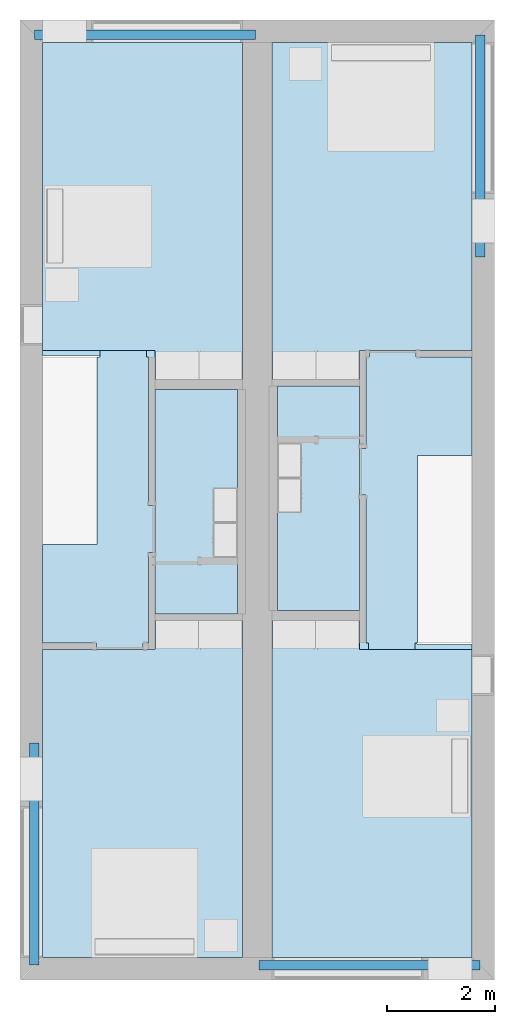
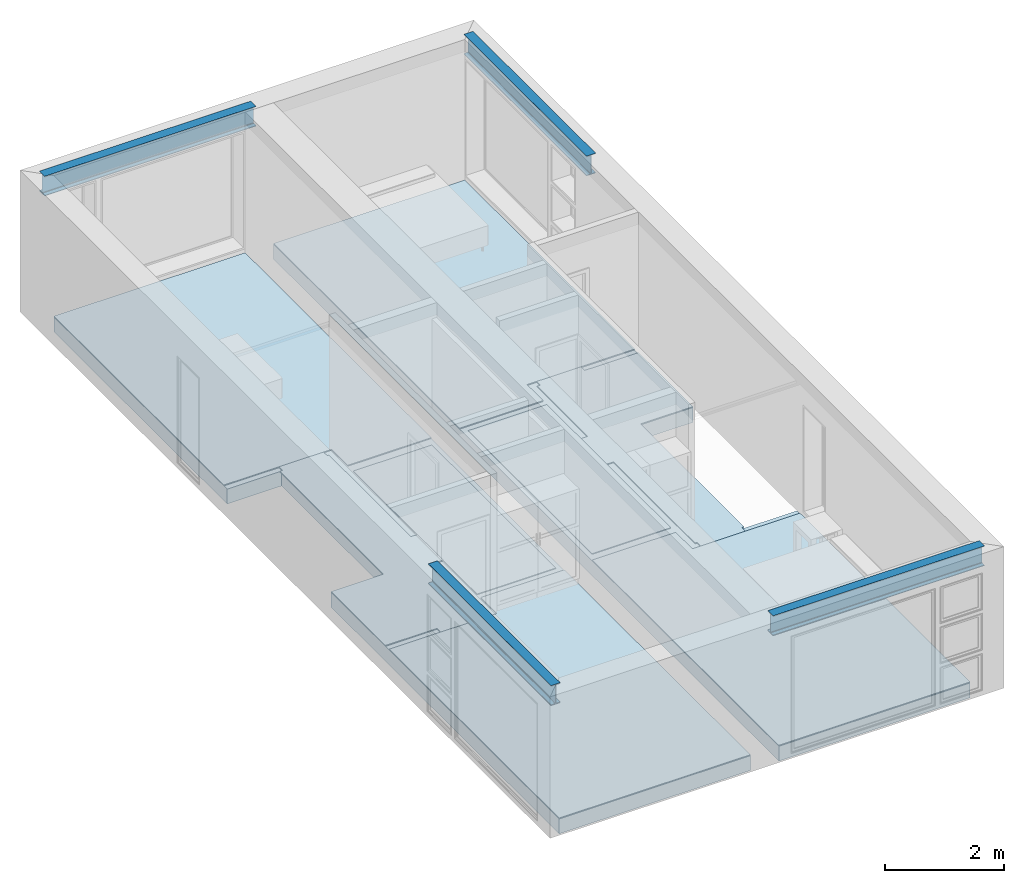
# One storey, part 1 of 16: 10 slabs, 4 beams.
"""IFC2X3 building model written with IfcOpenShell, lengths in metres."""

import ifcopenshell
import ifcopenshell.guid

model = None  # the IFC model being written
_history = None  # IfcOwnerHistory: only IFC2X3 demands one
_inside = {}  # id of a spatial element -> (the spatial element, [elements in it])
_under = {}  # id of a project, library or spatial element -> (it, [spatial elements below it])
_declared = {}  # id of a project -> (the project, [libraries it declares])
_typed = {}  # id of a type object -> (the type object, [elements of that type])
_made_of = {}  # id of a material, layer set ... -> (it, [elements and type objects made of it])


def new_model(schema):
    """Start an empty IFC model of exactly this schema.

    Asked for "IFC4X3", IfcOpenShell would pick the latest addendum, in which some entities
    have other attributes; the version numbers below select the first issue.
    IFC2X3 requires an IfcOwnerHistory on every rooted entity: one is made here for all.
    """
    global model, _history
    if schema == "IFC4X3":
        model = ifcopenshell.file(schema_version=(4, 3, 0, 0))
    else:
        model = ifcopenshell.file(schema=schema)
    _inside.clear()
    _under.clear()
    _declared.clear()
    _typed.clear()
    _made_of.clear()
    _history = None
    if model.schema == "IFC2X3":
        org = make("IfcOrganization", Name="unknown")
        user = make(
            "IfcPersonAndOrganization",
            ThePerson=make("IfcPerson", FamilyName="unknown"),
            TheOrganization=org,
        )
        app = make(
            "IfcApplication",
            ApplicationDeveloper=org,
            Version="unknown",
            ApplicationFullName="unknown",
            ApplicationIdentifier="unknown",
        )
        _history = make(
            "IfcOwnerHistory",
            OwningUser=user,
            OwningApplication=app,
            ChangeAction="ADDED",
            CreationDate=0,
        )
    return model


def make(cls, **values):
    """One entity of the class cls with the attributes given. An attribute that is None is left unset."""
    return model.create_entity(
        cls, **{name: value for name, value in values.items() if value is not None}
    )


def entity(cls, *values):
    """Any entity or typed value of the class cls, its attributes in the order of the schema. None: left unset."""
    e = model.create_entity(cls)
    for i, value in enumerate(values):
        if value is not None:
            e[i] = value
    return e


def rooted(cls, **values):
    """An entity with a GlobalId (a new one), such as an element, a storey or a relation."""
    return make(cls, GlobalId=ifcopenshell.guid.new(), OwnerHistory=_history, **values)


def si_unit(unit_type, name, prefix=None):
    """IfcSIUnit, for example si_unit("LENGTHUNIT", "METRE", prefix="MILLI")."""
    return make("IfcSIUnit", UnitType=unit_type, Prefix=prefix, Name=name)


def converted_unit(unit_type, name, factor, base, dimensions=None, offset=None):
    """IfcConversionBasedUnit, such as the inch: factor (a typed value) times the base unit."""
    return make(
        "IfcConversionBasedUnit"
        if offset is None
        else "IfcConversionBasedUnitWithOffset",
        ConversionOffset=offset,
        Dimensions=None
        if dimensions is None
        else entity("IfcDimensionalExponents", *dimensions),
        UnitType=unit_type,
        Name=name,
        ConversionFactor=make(
            "IfcMeasureWithUnit", ValueComponent=factor, UnitComponent=base
        ),
    )


def assignment(units):
    """IfcUnitAssignment: the units of a project."""
    return None if units is None else make("IfcUnitAssignment", Units=units)


def point(xyz):
    """IfcCartesianPoint."""
    return None if xyz is None else make("IfcCartesianPoint", Coordinates=xyz)


def direction(xyz):
    """IfcDirection."""
    return None if xyz is None else make("IfcDirection", DirectionRatios=xyz)


def frame(location, z_axis=None, x_axis=None):
    """IfcAxis2Placement3D, a coordinate frame: its origin and axes. An axis left out is left unset."""
    return make(
        "IfcAxis2Placement3D",
        Location=point(location),
        Axis=direction(z_axis),
        RefDirection=direction(x_axis),
    )


def frame_2d(location, x_axis=None):
    """IfcAxis2Placement2D, a coordinate frame in the plane: its origin and x axis."""
    return make(
        "IfcAxis2Placement2D", Location=point(location), RefDirection=direction(x_axis)
    )


def origin():
    """The frame at (0, 0, 0) with its axes left unset."""
    return frame((0.0, 0.0, 0.0))


def place(relative_to, where):
    """IfcLocalPlacement: puts the frame where relative to a parent placement (None: the world)."""
    return make(
        "IfcLocalPlacement", PlacementRelTo=relative_to, RelativePlacement=where
    )


def context(
    kind, dimensions, precision=None, world=None, true_north=None, identifier=None
):
    """IfcGeometricRepresentationContext, for example the 3D "Model" context."""
    return make(
        "IfcGeometricRepresentationContext",
        ContextIdentifier=identifier,
        ContextType=kind,
        CoordinateSpaceDimension=dimensions,
        Precision=precision,
        WorldCoordinateSystem=world,
        TrueNorth=true_north,
    )


def project(units=None, contexts=None):
    """IfcProject with its units and contexts."""
    return rooted(
        "IfcProject",
        Name="project",
        RepresentationContexts=contexts,
        UnitsInContext=assignment(units),
    )


def spatial(cls, under=None, at=None, **own):
    """A site, building, storey or space (cls), placed at a placement, below another one or the project."""
    s = rooted(cls, ObjectPlacement=at, **own)
    if under is not None:
        _under.setdefault(under.id(), (under, []))[1].append(s)
    return s


def polyline(points):
    """IfcPolyline through the points."""
    return make("IfcPolyline", Points=[point(p) for p in points])


def circle_curve(where, radius):
    """IfcCircle in the frame where."""
    return make("IfcCircle", Position=where, Radius=radius)


def parameter(value):
    """IfcParameterValue: where a trimmed curve begins or ends, as a parameter of its basis curve."""
    return model.create_entity("IfcParameterValue", value)


def trimmed(basis, trim1, trim2, sense, master):
    """IfcTrimmedCurve: the piece of a basis curve between two trims."""
    return make(
        "IfcTrimmedCurve",
        BasisCurve=basis,
        Trim1=trim1,
        Trim2=trim2,
        SenseAgreement=sense,
        MasterRepresentation=master,
    )


def segment(curve, same_sense, transition):
    """IfcCompositeCurveSegment."""
    return make(
        "IfcCompositeCurveSegment",
        Transition=transition,
        SameSense=same_sense,
        ParentCurve=curve,
    )


def composite_curve(segments, self_intersect=None):
    """IfcCompositeCurve: segments joined end to end."""
    return make("IfcCompositeCurve", Segments=segments, SelfIntersect=self_intersect)


def profile(cls, at=None, kind="AREA", **sizes):
    """A parametric profile (cls). Its sizes go by their IFC names, for example OverallWidth=200.0."""
    return make(cls, ProfileType=kind, Position=at, **sizes)


def rectangle(**sizes):
    """IfcRectangleProfileDef."""
    return profile("IfcRectangleProfileDef", **sizes)


def outline(outer, holes=None, kind="AREA"):
    """IfcArbitraryClosedProfileDef: a profile drawn as a closed curve; with holes, ...WithVoids."""
    if holes is None:
        return make("IfcArbitraryClosedProfileDef", ProfileType=kind, OuterCurve=outer)
    return make(
        "IfcArbitraryProfileDefWithVoids",
        ProfileType=kind,
        OuterCurve=outer,
        InnerCurves=holes,
    )


def extrude(swept, where, along, depth):
    """IfcExtrudedAreaSolid: the profile swept, set in the frame where, extruded along a direction by depth."""
    return make(
        "IfcExtrudedAreaSolid",
        SweptArea=swept,
        Position=where,
        ExtrudedDirection=direction(along),
        Depth=depth,
    )


def shape(context_of_items, identifier, shape_type, items):
    """IfcShapeRepresentation: the items that make up one representation, for example the "Body"."""
    return make(
        "IfcShapeRepresentation",
        ContextOfItems=context_of_items,
        RepresentationIdentifier=identifier,
        RepresentationType=shape_type,
        Items=items,
    )


def material(Name=None, Category=None):
    """IfcMaterial."""
    return make("IfcMaterial", Name=Name, Category=Category)


def layer(
    of_material, thickness, ventilated=None, Name=None, Category=None, Priority=None
):
    """IfcMaterialLayer: one layer of a wall or slab, of a material (None: an air gap)."""
    return make(
        "IfcMaterialLayer",
        Material=of_material,
        LayerThickness=thickness,
        IsVentilated=ventilated,
        Name=Name,
        Category=Category,
        Priority=Priority,
    )


def layer_set(layers, Name=None):
    """IfcMaterialLayerSet."""
    return make("IfcMaterialLayerSet", MaterialLayers=layers, LayerSetName=Name)


def layer_usage(for_layer_set, set_direction, sense, offset, extent=None):
    """IfcMaterialLayerSetUsage: how a layer set lies in its element."""
    return make(
        "IfcMaterialLayerSetUsage",
        ForLayerSet=for_layer_set,
        LayerSetDirection=set_direction,
        DirectionSense=sense,
        OffsetFromReferenceLine=offset,
        ReferenceExtent=extent,
    )


def made_of(thing, what):
    """Note that an element or type object is made of a material, layer set ...; save() writes the relation."""
    if what is not None:
        _made_of.setdefault(what.id(), (what, []))[1].append(thing)
    return thing


def element(
    cls,
    number,
    at=None,
    inside=None,
    cuts=None,
    type_object=None,
    material=None,
    context=None,
    identifier="Body",
    shape_type=None,
    held_by="IfcProductDefinitionShape",
    body=None,
    shapes=None,
    **own,
):
    """One element of the class cls, such as IfcWall. Its Tag is "e" and its number.

    at: its placement. inside: the storey or other place that contains it. cuts: it is an
    opening in that element (IfcRelVoidsElement). A single representation is given by context,
    identifier, shape_type and body (its items); several are given by shapes. held_by: the class
    of the entity that holds the representations. save() writes the other relations.
    """
    e = rooted(cls, Tag="e%d" % number, ObjectPlacement=at, **own)
    if body is not None:
        shapes = [shape(context, identifier, shape_type, body)]
    if shapes is not None:
        e.Representation = make(held_by, Representations=shapes)
    if inside is not None:
        _inside.setdefault(inside.id(), (inside, []))[1].append(e)
    if cuts is not None:
        rooted(
            "IfcRelVoidsElement", RelatingBuildingElement=cuts, RelatedOpeningElement=e
        )
    if type_object is not None:
        _typed.setdefault(type_object.id(), (type_object, []))[1].append(e)
    return made_of(e, material)


def aggregate(whole, parts):
    """IfcRelAggregates: a whole, such as a stair, and the parts it consists of."""
    return rooted("IfcRelAggregates", RelatingObject=whole, RelatedObjects=parts)


def save(model, path):
    """Write the relations noted so far, then the file.

    IfcRelAggregates (storeys below a building ...), IfcRelContainedInSpatialStructure (elements
    in a storey), IfcRelDefinesByType, IfcRelAssociatesMaterial and IfcRelDeclares: one each for
    every whole, place, type object, material and project.
    """
    for whole, parts in _under.values():
        aggregate(whole, parts)
    for where, things in _inside.values():
        rooted(
            "IfcRelContainedInSpatialStructure",
            RelatedElements=things,
            RelatingStructure=where,
        )
    for kind, things in _typed.values():
        rooted("IfcRelDefinesByType", RelatedObjects=things, RelatingType=kind)
    for what, things in _made_of.values():
        rooted("IfcRelAssociatesMaterial", RelatedObjects=things, RelatingMaterial=what)
    for by, libraries in _declared.values():
        rooted("IfcRelDeclares", RelatingContext=by, RelatedDefinitions=libraries)
    model.write(path)


model = new_model("IFC2X3")

# Units and contexts
model_context = context("Model", 3, precision=1e-09, world=origin())
plan_context = context("Plan", 3, precision=1e-09, world=origin())
ifc_project = project(units=[si_unit("LENGTHUNIT", "METRE"), si_unit("AREAUNIT", "SQUARE_METRE"), si_unit("VOLUMEUNIT", "CUBIC_METRE"), converted_unit("PLANEANGLEUNIT", "DEGREE", entity("IfcRatioMeasure", 0.01745329251994328), si_unit("PLANEANGLEUNIT", "RADIAN"), dimensions=[0, 0, 0, 0, 0, 0, 0]), si_unit("TIMEUNIT", "SECOND")], contexts=[model_context, plan_context])

# Site, building, storey
site_placement = place(None, origin())
site = spatial("IfcSite", under=ifc_project, at=site_placement, CompositionType="ELEMENT")
building_placement = place(site_placement, origin())
building = spatial("IfcBuilding", under=site, at=building_placement, CompositionType="ELEMENT")
storey_placement = place(building_placement, frame((0.0, 0.0, 3.100000000000196)))
storey = spatial("IfcBuildingStorey", under=building, at=storey_placement, Name="Level 2", CompositionType="ELEMENT", Elevation=3.100000000000196)

# Beams
ifc_material_1 = material(Name="Metal - Steel - 345 MPa")
beam_1_placement = place(storey_placement, frame((0.2666128795750488, -13.40172007136963, 2.900000000000012), z_axis=(0.0, 0.0, 1.0), x_axis=(-1.0, 0.0, 0.0)))
element("IfcBeam", 1, at=beam_1_placement, inside=storey, material=ifc_material_1, context=model_context, shape_type="SweptSolid", body=[
    extrude(outline(composite_curve([segment(polyline([(0.1906999999999978, -0.08900000000000018), (0.2034999999999992, -0.08900000000000018)]), True, "CONTINUOUS"), segment(polyline([(0.2034999999999992, -0.08900000000000018), (0.2034999999999992, 0.08900000000000004)]), True, "CONTINUOUS"), segment(polyline([(0.2034999999999992, 0.08900000000000004), (0.1906999999999978, 0.08900000000000004)]), True, "CONTINUOUS"), segment(polyline([(0.1906999999999978, 0.08900000000000004), (0.1906999999999978, 0.02104999999999999)]), True, "CONTINUOUS"), segment(trimmed(circle_curve(frame_2d((0.1734999999999985, 0.02104999999999992), x_axis=(1.0, 0.0)), 0.0172), [parameter(269.9999999999999)], [parameter(359.9999999999997)], True, "PARAMETER"), False, "CONTINUOUS"), segment(polyline([(0.1734999999999985, 0.003849999999999937), (-0.1735000000000017, 0.003849999999999937)]), True, "CONTINUOUS"), segment(trimmed(circle_curve(frame_2d((-0.1735000000000017, 0.02104999999999992), x_axis=(0.0, -1.0)), 0.0172), [parameter(269.9999999999999)], [parameter(359.9999999999999)], True, "PARAMETER"), False, "CONTINUOUS"), segment(polyline([(-0.1907000000000021, 0.02104999999999999), (-0.1907000000000021, 0.08900000000000004)]), True, "CONTINUOUS"), segment(polyline([(-0.1907000000000021, 0.08900000000000004), (-0.2035000000000014, 0.08900000000000004)]), True, "CONTINUOUS"), segment(polyline([(-0.2035000000000014, 0.08900000000000007), (-0.2035000000000014, -0.08899999999999963)]), True, "CONTINUOUS"), segment(polyline([(-0.2035000000000014, -0.08899999999999963), (-0.1907000000000021, -0.08899999999999963)]), True, "CONTINUOUS"), segment(polyline([(-0.1907000000000021, -0.08899999999999963), (-0.1907000000000021, -0.02105000000000012)]), True, "CONTINUOUS"), segment(trimmed(circle_curve(frame_2d((-0.1735000000000017, -0.02105000000000016), x_axis=(-1.0, 0.0)), 0.0172), [parameter(269.9999999999999)], [parameter(0.0)], True, "PARAMETER"), False, "CONTINUOUS"), segment(polyline([(-0.1735000000000017, -0.00385000000000014), (0.1734999999999985, -0.00385000000000014)]), True, "CONTINUOUS"), segment(trimmed(circle_curve(frame_2d((0.1734999999999985, -0.02105000000000016), x_axis=(0.0, 1.0)), 0.0172), [parameter(269.9999999999999)], [parameter(5.088887490341632e-14)], True, "PARAMETER"), False, "CONTINUOUS"), segment(polyline([(0.1906999999999978, -0.02105000000000012), (0.1906999999999978, -0.08900000000000018)]), True, "CONTINUOUS")], self_intersect=False)), frame((0.0, 4.121279928630347, -0.2035000000000068), z_axis=(0.0, -1.0, 0.0), x_axis=(0.0, 0.0, -1.0)), (0.0, 0.0, 1.0), 4.121279928630352),
])
beam_2_placement = place(storey_placement, frame((4.428954328744266, -17.52876686297367, 2.900000000000012), z_axis=(0.0, 0.0, 1.0), x_axis=(0.0, -1.0, 0.0)))
element("IfcBeam", 2, at=beam_2_placement, inside=storey, material=ifc_material_1, context=model_context, shape_type="SweptSolid", body=[
    extrude(outline(composite_curve([segment(polyline([(-0.08900000000000359, -0.1907), (-0.08900000000000359, -0.2035000000000014)]), True, "CONTINUOUS"), segment(polyline([(-0.08900000000000359, -0.2035000000000014), (0.0889999999999971, -0.2035000000000014)]), True, "CONTINUOUS"), segment(polyline([(0.0889999999999971, -0.2035000000000014), (0.0889999999999971, -0.1907)]), True, "CONTINUOUS"), segment(polyline([(0.0889999999999971, -0.1907), (0.02104999999999738, -0.1907)]), True, "CONTINUOUS"), segment(trimmed(circle_curve(frame_2d((0.02104999999999738, -0.1735000000000007), x_axis=(0.0, -1.0)), 0.0172), [parameter(269.9999999999999)], [parameter(359.9999999999997)], True, "PARAMETER"), False, "CONTINUOUS"), segment(polyline([(0.003849999999996959, -0.1735000000000007), (0.003849999999996959, 0.1734999999999995)]), True, "CONTINUOUS"), segment(trimmed(circle_curve(frame_2d((0.02104999999999738, 0.1734999999999995), x_axis=(-1.0, 0.0)), 0.0172), [parameter(269.9999999999999)], [parameter(359.9999999999999)], True, "PARAMETER"), False, "CONTINUOUS"), segment(polyline([(0.02104999999999522, 0.1907), (0.0889999999999971, 0.1907)]), True, "CONTINUOUS"), segment(polyline([(0.0889999999999971, 0.1907), (0.0889999999999971, 0.2034999999999992)]), True, "CONTINUOUS"), segment(polyline([(0.0889999999999971, 0.2034999999999992), (-0.08900000000000359, 0.2034999999999992)]), True, "CONTINUOUS"), segment(polyline([(-0.08900000000000359, 0.2034999999999992), (-0.08900000000000359, 0.1907)]), True, "CONTINUOUS"), segment(polyline([(-0.08900000000000359, 0.1907), (-0.02105000000000388, 0.1907)]), True, "CONTINUOUS"), segment(trimmed(circle_curve(frame_2d((-0.02105000000000388, 0.1734999999999995), x_axis=(0.0, 1.0)), 0.0172), [parameter(269.9999999999999)], [parameter(0.0)], True, "PARAMETER"), False, "CONTINUOUS"), segment(polyline([(-0.003850000000003457, 0.1734999999999995), (-0.003850000000003457, -0.1735000000000007)]), True, "CONTINUOUS"), segment(trimmed(circle_curve(frame_2d((-0.02105000000000388, -0.1735000000000007), x_axis=(1.0, 0.0)), 0.0172), [parameter(269.9999999999999)], [parameter(5.088887490341632e-14)], True, "PARAMETER"), False, "CONTINUOUS"), segment(polyline([(-0.02105000000000388, -0.1907), (-0.08900000000000359, -0.1907)]), True, "CONTINUOUS")], self_intersect=False)), frame((0.0, 0.0, -0.2035000000000046), z_axis=(0.0, -1.0, 0.0), x_axis=(1.0, 0.0, 0.0)), (0.0, 0.0, -1.0), 4.100000000000001),
])
beam_3_placement = place(storey_placement, frame((8.533387120424969, -4.398279928630386, 2.900000000000012)))
element("IfcBeam", 3, at=beam_3_placement, inside=storey, material=ifc_material_1, context=model_context, shape_type="SweptSolid", body=[
    extrude(outline(composite_curve([segment(polyline([(-0.08900000000000033, -0.1907), (-0.08900000000000033, -0.2035000000000014)]), True, "CONTINUOUS"), segment(polyline([(-0.08900000000000033, -0.2035000000000014), (0.08899999999999927, -0.2035000000000014)]), True, "CONTINUOUS"), segment(polyline([(0.08899999999999927, -0.2035000000000014), (0.08899999999999927, -0.1907)]), True, "CONTINUOUS"), segment(polyline([(0.08899999999999927, -0.1907), (0.02104999999999955, -0.1907)]), True, "CONTINUOUS"), segment(trimmed(circle_curve(frame_2d((0.02104999999999955, -0.1735000000000007), x_axis=(0.0, -1.0)), 0.0172), [parameter(269.9999999999999)], [parameter(359.9999999999997)], True, "PARAMETER"), False, "CONTINUOUS"), segment(polyline([(0.003849999999999125, -0.1735000000000007), (0.003849999999999125, 0.1734999999999995)]), True, "CONTINUOUS"), segment(trimmed(circle_curve(frame_2d((0.02104999999999955, 0.1734999999999995), x_axis=(-1.0, 0.0)), 0.0172), [parameter(269.9999999999999)], [parameter(359.9999999999999)], True, "PARAMETER"), False, "CONTINUOUS"), segment(polyline([(0.02104999999999955, 0.1907), (0.08899999999999927, 0.1907)]), True, "CONTINUOUS"), segment(polyline([(0.08899999999999927, 0.1907), (0.08899999999999927, 0.2034999999999992)]), True, "CONTINUOUS"), segment(polyline([(0.08899999999999927, 0.2034999999999992), (-0.08900000000000033, 0.2034999999999992)]), True, "CONTINUOUS"), segment(polyline([(-0.08900000000000033, 0.2034999999999992), (-0.08900000000000033, 0.1907)]), True, "CONTINUOUS"), segment(polyline([(-0.08900000000000033, 0.1907), (-0.02105000000000063, 0.1907)]), True, "CONTINUOUS"), segment(trimmed(circle_curve(frame_2d((-0.02105000000000063, 0.1734999999999995), x_axis=(0.0, 1.0)), 0.0172), [parameter(269.9999999999999)], [parameter(0.0)], True, "PARAMETER"), False, "CONTINUOUS"), segment(polyline([(-0.003850000000000208, 0.1734999999999995), (-0.003850000000000208, -0.1735000000000007)]), True, "CONTINUOUS"), segment(trimmed(circle_curve(frame_2d((-0.02105000000000063, -0.1735000000000007), x_axis=(1.0, 0.0)), 0.0172), [parameter(269.9999999999999)], [parameter(5.088887490341632e-14)], True, "PARAMETER"), False, "CONTINUOUS"), segment(polyline([(-0.02105000000000063, -0.1907), (-0.08900000000000033, -0.1907)]), True, "CONTINUOUS")], self_intersect=False)), frame((0.0, 0.0, -0.2035000000000046), z_axis=(0.0, -1.0, 0.0), x_axis=(1.0, 0.0, 0.0)), (0.0, 0.0, -1.0), 4.121279928630351),
])
beam_4_placement = place(storey_placement, frame((4.371045671255766, -0.2712331370263279, 2.900000000000012), z_axis=(0.0, 0.0, 1.0), x_axis=(0.0, 1.0, 0.0)))
element("IfcBeam", 4, at=beam_4_placement, inside=storey, material=ifc_material_1, context=model_context, shape_type="SweptSolid", body=[
    extrude(outline(composite_curve([segment(polyline([(0.1906999999999978, -0.08900000000000008), (0.2034999999999992, -0.08900000000000008)]), True, "CONTINUOUS"), segment(polyline([(0.2034999999999992, -0.08900000000000008), (0.2034999999999992, 0.08900000000000013)]), True, "CONTINUOUS"), segment(polyline([(0.2034999999999992, 0.08900000000000013), (0.1906999999999978, 0.08900000000000013)]), True, "CONTINUOUS"), segment(polyline([(0.1906999999999978, 0.08900000000000013), (0.1906999999999978, 0.02105000000000009)]), True, "CONTINUOUS"), segment(trimmed(circle_curve(frame_2d((0.1734999999999985, 0.02105000000000002), x_axis=(1.0, 0.0)), 0.0172), [parameter(269.9999999999999)], [parameter(359.9999999999997)], True, "PARAMETER"), False, "CONTINUOUS"), segment(polyline([(0.1734999999999985, 0.003850000000000039), (-0.1735000000000017, 0.003850000000000039)]), True, "CONTINUOUS"), segment(trimmed(circle_curve(frame_2d((-0.1735000000000017, 0.02105000000000002), x_axis=(0.0, -1.0)), 0.0172), [parameter(269.9999999999999)], [parameter(359.9999999999999)], True, "PARAMETER"), False, "CONTINUOUS"), segment(polyline([(-0.1907000000000021, 0.02105000000000009), (-0.1907000000000021, 0.08900000000000013)]), True, "CONTINUOUS"), segment(polyline([(-0.1907000000000021, 0.08900000000000013), (-0.2035000000000014, 0.08900000000000013)]), True, "CONTINUOUS"), segment(polyline([(-0.2035000000000014, 0.08900000000000016), (-0.2035000000000014, -0.08899999999999954)]), True, "CONTINUOUS"), segment(polyline([(-0.2035000000000014, -0.08899999999999954), (-0.1907000000000021, -0.08899999999999954)]), True, "CONTINUOUS"), segment(polyline([(-0.1907000000000021, -0.08899999999999954), (-0.1907000000000021, -0.02105000000000002)]), True, "CONTINUOUS"), segment(trimmed(circle_curve(frame_2d((-0.1735000000000017, -0.02105000000000006), x_axis=(-1.0, 0.0)), 0.0172), [parameter(269.9999999999999)], [parameter(0.0)], True, "PARAMETER"), False, "CONTINUOUS"), segment(polyline([(-0.1735000000000017, -0.003850000000000038), (0.1734999999999985, -0.003850000000000038)]), True, "CONTINUOUS"), segment(trimmed(circle_curve(frame_2d((0.1734999999999985, -0.02105000000000006), x_axis=(0.0, 1.0)), 0.0172), [parameter(269.9999999999999)], [parameter(5.088887490341632e-14)], True, "PARAMETER"), False, "CONTINUOUS"), segment(polyline([(0.1906999999999978, -0.02105000000000002), (0.1906999999999978, -0.08900000000000008)]), True, "CONTINUOUS")], self_intersect=False)), frame((0.0, 4.1, -0.2035000000000068), z_axis=(0.0, -1.0, 0.0), x_axis=(0.0, 0.0, -1.0)), (0.0, 0.0, 1.0), 4.100000000000001),
])

# Slabs
ifc_material_2 = material(Name="Wood - Sheathing - plywood")
ifc_layer_1 = layer(ifc_material_2, 0.019)
ifc_material_3 = material(Name="Wood - Dimensional Lumber")
ifc_layer_2 = layer(ifc_material_3, 0.286)
ifc_layer_set_1 = layer_set([ifc_layer_1, ifc_layer_2], Name="Floor:Residential - Wood Joist with")
ifc_layer_usage_1 = layer_usage(ifc_layer_set_1, "AXIS3", "POSITIVE", 0.0)
slab_1_placement = place(storey_placement, frame((0.4169999999999994, -17.38299999999999, -0.3049999999999997)))
element("IfcSlab", 5, at=slab_1_placement, inside=storey, material=ifc_layer_usage_1, Name="Floor:Residential - Wood Joist with", ObjectType="Floor:Residential - Wood Joist with", PredefinedType="FLOOR", context=model_context, shape_type="SweptSolid", body=[
    extrude(outline(polyline([(-1.854000000000013, 8.48299999999998), (-1.853999999999986, -8.482999999999993), (1.853999999999987, -8.482999999999981), (1.853999999999987, -0.8250000000000085), (0.799599999999962, -0.8250000000000117), (0.7995999999999563, 2.665999999999988), (1.853999999999987, 2.665999999999991), (1.853999999999986, 8.482999999999993), (-1.854000000000013, 8.48299999999998)])), frame((1.853999999999987, 8.482999999999993, 0.3049999999999994), z_axis=(0.0, 0.0, -1.0), x_axis=(-1.0, 0.0, 0.0)), (0.0, 0.0, 1.0), 0.305),
])
ifc_layer_usage_2 = layer_usage(ifc_layer_set_1, "AXIS3", "POSITIVE", 0.0)
slab_2_placement = place(storey_placement, frame((4.674999999999998, -17.383, -0.3049999999999997)))
element("IfcSlab", 6, at=slab_2_placement, inside=storey, material=ifc_layer_usage_2, Name="Floor:Residential - Wood Joist with", ObjectType="Floor:Residential - Wood Joist with", PredefinedType="FLOOR", context=model_context, shape_type="SweptSolid", body=[
    extrude(outline(polyline([(-1.854000000000013, 8.48299999999998), (-1.854000000000001, 0.8250000000000031), (-0.829600000000002, 0.8250000000000063), (-0.8295999999999966, -2.665999999999991), (-1.853999999999995, -2.665999999999995), (-1.853999999999986, -8.482999999999992), (1.853999999999987, -8.482999999999981), (1.853999999999986, 8.482999999999992), (-1.854000000000013, 8.48299999999998)])), frame((1.853999999999987, 8.482999999999992, 0.3049999999999994), z_axis=(0.0, 0.0, -1.0), x_axis=(-1.0, 0.0, 0.0)), (0.0, 0.0, 1.0), 0.305),
])
ifc_material_4 = material(Name="Wood - Flooring")
ifc_layer_3 = layer(ifc_material_4, 0.016)
ifc_material_5 = material(Name="Insulation / Thermal Barriers - Semi-rigid insulation")
ifc_layer_4 = layer(ifc_material_5, 0.003)
ifc_layer_set_2 = layer_set([ifc_layer_3, ifc_layer_4], Name="Floor:Finish Floor - Wood")
ifc_layer_usage_3 = layer_usage(ifc_layer_set_2, "AXIS3", "POSITIVE", 0.0)
slab_3_placement = place(storey_placement, frame((0.4169999999999989, -6.666000000000008, 0.0)))
element("IfcSlab", 7, at=slab_3_placement, inside=storey, material=ifc_layer_usage_3, Name="Floor:Finish Floor - Wood", ObjectType="Floor:Finish Floor - Wood", PredefinedType="FLOOR", context=model_context, shape_type="SweptSolid", body=[
    extrude(outline(polyline([(1.853999999999995, 3.124500000000004), (-1.854000000000005, 3.124499999999991), (-1.853999999999995, -3.124500000000002), (-0.235000000000004, -3.124499999999999), (-0.235000000000004, -2.584499999999999), (1.853999999999996, -2.584499999999999), (1.853999999999995, 3.124500000000004)])), frame((1.853999999999996, 3.124500000000002, 0.01899999999999947), z_axis=(0.0, 0.0, -1.0), x_axis=(-1.0, 0.0, 0.0)), (0.0, 0.0, 1.0), 0.01900000000000001),
])
ifc_layer_usage_4 = layer_usage(ifc_layer_set_2, "AXIS3", "POSITIVE", 0.0)
slab_4_placement = place(storey_placement, frame((4.675, -6.666000000000003, 0.0)))
element("IfcSlab", 8, at=slab_4_placement, inside=storey, material=ifc_layer_usage_4, Name="Floor:Finish Floor - Wood", ObjectType="Floor:Finish Floor - Wood", PredefinedType="FLOOR", context=model_context, shape_type="SweptSolid", body=[
    extrude(outline(polyline([(-1.854000000000005, 3.124499999999986), (-1.853999999999995, -2.584499999999996), (0.2349999999999791, -2.58449999999999), (0.2349999999999791, -3.124499999999991), (1.853999999999994, -3.124499999999991), (1.853999999999994, 3.124499999999997), (-1.854000000000005, 3.124499999999986)])), frame((1.853999999999994, 3.124499999999991, 0.01899999999999947), z_axis=(0.0, 0.0, -1.0), x_axis=(-1.0, 0.0, 0.0)), (0.0, 0.0, 1.0), 0.01900000000000001),
])
ifc_layer_usage_5 = layer_usage(ifc_layer_set_2, "AXIS3", "POSITIVE", 0.0)
slab_5_placement = place(storey_placement, frame((4.674999999999972, -17.383, 0.0)))
element("IfcSlab", 9, at=slab_5_placement, inside=storey, material=ifc_layer_usage_5, Name="Floor:Finish Floor - Wood", ObjectType="Floor:Finish Floor - Wood", PredefinedType="FLOOR", context=model_context, shape_type="SweptSolid", body=[
    extrude(outline(polyline([(-1.854000000000023, 2.576499999999997), (-1.853999999999994, -3.132499999999998), (1.854000000000005, -3.132499999999987), (1.853999999999995, 3.132499999999996), (0.2349999999999617, 3.132499999999996), (0.2349999999999617, 2.576499999999997), (-1.854000000000023, 2.576499999999997)])), frame((1.854000000000005, 3.132499999999998, 0.01899999999999947), z_axis=(0.0, 0.0, -1.0), x_axis=(-1.0, 0.0, 0.0)), (0.0, 0.0, 1.0), 0.01900000000000001),
])
ifc_layer_usage_6 = layer_usage(ifc_layer_set_2, "AXIS3", "POSITIVE", 0.0)
slab_6_placement = place(storey_placement, frame((0.4169999999999994, -17.38299999999999, 0.0)))
element("IfcSlab", 10, at=slab_6_placement, inside=storey, material=ifc_layer_usage_6, Name="Floor:Finish Floor - Wood", ObjectType="Floor:Finish Floor - Wood", PredefinedType="FLOOR", context=model_context, shape_type="SweptSolid", body=[
    extrude(outline(polyline([(-1.853999999999981, -3.124499999999998), (1.853999999999992, -3.124499999999987), (1.853999999999992, 2.584499999999991), (-0.2350000000000067, 2.584499999999984), (-0.2350000000000067, 3.124499999999985), (-1.854000000000009, 3.124499999999985), (-1.853999999999981, -3.124499999999998)])), frame((1.853999999999992, 3.124499999999998, 0.01899999999999947), z_axis=(0.0, 0.0, -1.0), x_axis=(-1.0, 0.0, 0.0)), (0.0, 0.0, 1.0), 0.01900000000000001),
])
ifc_layer_usage_7 = layer_usage(ifc_layer_set_2, "AXIS3", "POSITIVE", 0.0)
slab_7_placement = place(storey_placement, frame((0.4169999999999994, -11.674, 0.0)))
element("IfcSlab", 11, at=slab_7_placement, inside=storey, material=ifc_layer_usage_7, Name="Floor:Finish Floor - Wood", ObjectType="Floor:Finish Floor - Wood", PredefinedType="FLOOR", context=model_context, shape_type="SweptSolid", body=[
    extrude(outline(polyline([(-0.9205000000000011, -0.1060511785105842), (-1.0445, -0.1060511785105842), (-1.0445, -0.9700511785105828), (-0.9205000000000011, -0.9700511785105828), (-0.9205000000000011, -2.649999999999998), (-0.8204999999999938, -2.649999999999998), (-0.8204999999999935, -2.774), (0.04350000000000635, -2.773999999999995), (0.04350000000000608, -2.649999999999998), (1.0445, -2.649999999999993), (1.0445, -0.8249999999999998), (0.03009999999999938, -0.825000000000002), (0.03009999999999126, 2.649999999999999), (-0.02179999999999559, 2.649999999999999), (-0.02179999999999613, 2.773999999999999), (-0.8857999999999965, 2.773999999999997), (-0.885799999999996, 2.650000000000002), (-0.9205000000000011, 2.650000000000002), (-0.9205000000000011, -0.1060511785105842)])), frame((1.0445, 2.774, 0.01899999999999947), z_axis=(0.0, 0.0, -1.0), x_axis=(-1.0, 0.0, 0.0)), (0.0, 0.0, 1.0), 0.01900000000000001),
])
ifc_layer_usage_8 = layer_usage(ifc_layer_set_2, "AXIS3", "POSITIVE", 0.0)
slab_8_placement = place(storey_placement, frame((6.294000000000013, -11.67400000000001, 0.0)))
element("IfcSlab", 12, at=slab_8_placement, inside=storey, material=ifc_layer_usage_8, Name="Floor:Finish Floor - Wood", ObjectType="Floor:Finish Floor - Wood", PredefinedType="FLOOR", context=model_context, shape_type="SweptSolid", body=[
    extrude(outline(polyline([(0.9205000000000149, 0.09061576492848053), (1.044499999999974, 0.09061576492848161), (1.044499999999972, 0.9546157649284801), (0.9204999999999943, 0.9546157649284801), (0.9204999999999889, 2.650000000000002), (0.8604999999999787, 2.650000000000002), (0.8604999999999787, 2.774000000000003), (-0.003500000000020862, 2.773999999999997), (-0.003500000000020862, 2.649999999999998), (-1.044499999999993, 2.649999999999991), (-1.044499999999988, 0.8249999999999976), (-0.03010000000000182, 0.8250000000000031), (-0.03009999999998233, -2.649999999999998), (0.01720000000000151, -2.649999999999998), (0.01720000000000259, -2.773999999999997), (0.8812000000000033, -2.773999999999991), (0.8812000000000022, -2.649999999999989), (0.9205000000000235, -2.649999999999989), (0.9205000000000149, 0.09061576492848053)])), frame((1.044499999999974, 2.773999999999997, 0.01899999999999947), z_axis=(0.0, 0.0, -1.0), x_axis=(-1.0, 0.0, 0.0)), (0.0, 0.0, 1.0), 0.01900000000000001),
])
ifc_material_6 = material(Name="Ceramic Tile")
ifc_layer_5 = layer(ifc_material_6, 0.01)
ifc_material_7 = material(Name="Masonry - Grout")
ifc_layer_6 = layer(ifc_material_7, 0.003)
ifc_layer_set_3 = layer_set([ifc_layer_5, ifc_layer_6], Name="Floor:Finish Floor - Ceramic Tile")
ifc_layer_usage_9 = layer_usage(ifc_layer_set_3, "AXIS3", "POSITIVE", 0.0)
slab_9_placement = place(storey_placement, frame((2.505999999999992, -11.01, 0.0)))
element("IfcSlab", 13, at=slab_9_placement, inside=storey, material=ifc_layer_usage_9, Name="Floor:Finish Floor - Ceramic Tile", ObjectType="Floor:Finish Floor - Ceramic Tile", PredefinedType="FLOOR", context=model_context, shape_type="SweptSolid", body=[
    extrude(rectangle(XDim=4.16, YDim=1.523999999999994, at=frame_2d((0.0, 0.0), x_axis=(0.0, -1.0))), frame((0.7619999999999968, 2.080000000000001, 0.01299999999999921), z_axis=(0.0, 0.0, -1.0), x_axis=(-1.0, 0.0, 0.0)), (0.0, 0.0, 1.0), 0.01299999999999975),
])
ifc_layer_usage_10 = layer_usage(ifc_layer_set_3, "AXIS3", "POSITIVE", 0.0)
slab_10_placement = place(storey_placement, frame((4.769999999999986, -10.95000000000001, 0.0)))
element("IfcSlab", 14, at=slab_10_placement, inside=storey, material=ifc_layer_usage_10, Name="Floor:Finish Floor - Ceramic Tile", ObjectType="Floor:Finish Floor - Ceramic Tile", PredefinedType="FLOOR", context=model_context, shape_type="SweptSolid", body=[
    extrude(rectangle(XDim=4.160000000000009, YDim=1.524000000000014, at=frame_2d((0.0, 0.0), x_axis=(0.0, -1.0))), frame((0.7620000000000071, 2.080000000000005, 0.01299999999999921), z_axis=(0.0, 0.0, -1.0), x_axis=(-1.0, 0.0, 0.0)), (0.0, 0.0, 1.0), 0.01299999999999975),
])

save(model, "model.ifc")
